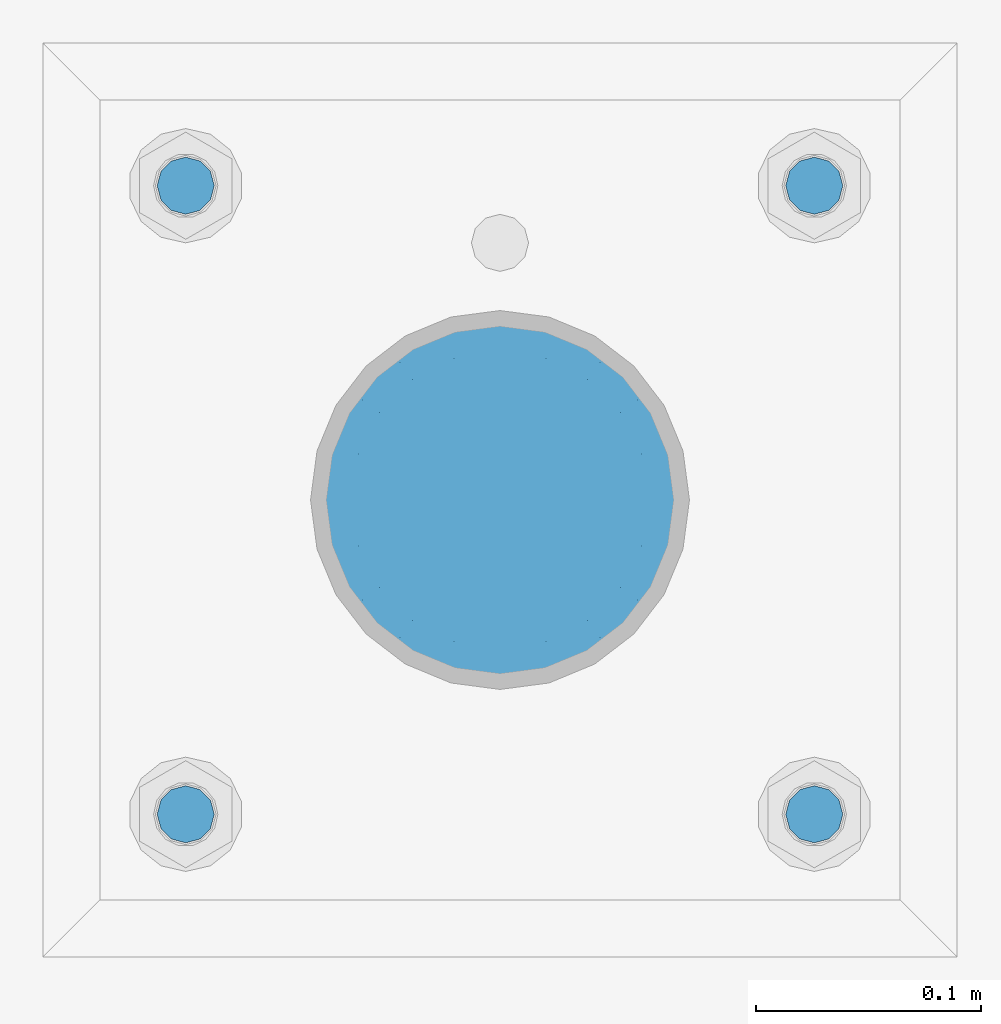
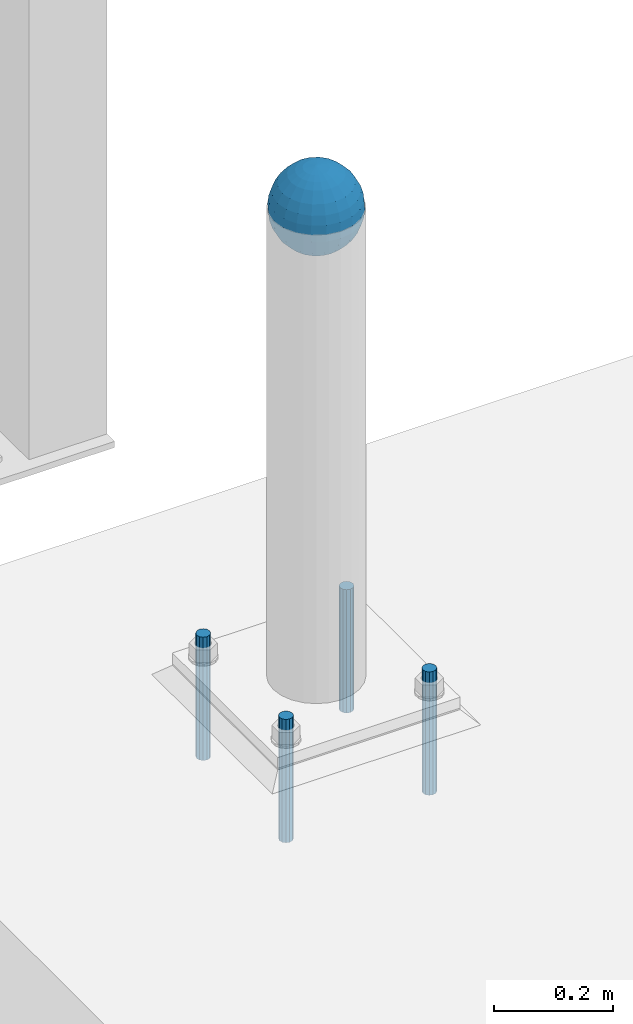
# One storey, part 1578 of 3843: 5 columns, 2 elements without a shape of their own.
"""IFC2X3 building model written with IfcOpenShell, lengths in millimetres."""

from ifc_helpers import new_model, si_unit, frame, origin_with_axes, place, context, subcontext, project, spatial, faceted_brep, material, type_object, element, aggregate, save


model = new_model("IFC2X3")

# Units and contexts
model_context = context("Model", 3, precision=1e-05, world=origin_with_axes())
body_context = subcontext(model_context, "Body", "Model", "MODEL_VIEW")
ifc_project = project(units=[si_unit("LENGTHUNIT", "METRE", prefix="MILLI"), si_unit("AREAUNIT", "SQUARE_METRE"), si_unit("VOLUMEUNIT", "CUBIC_METRE"), si_unit("MASSUNIT", "GRAM", prefix="KILO"), si_unit("TIMEUNIT", "SECOND"), si_unit("PLANEANGLEUNIT", "RADIAN"), si_unit("SOLIDANGLEUNIT", "STERADIAN"), si_unit("THERMODYNAMICTEMPERATUREUNIT", "DEGREE_CELSIUS"), si_unit("LUMINOUSINTENSITYUNIT", "LUMEN")], contexts=[model_context])

# Site, building, storey
site_placement = place(None, origin_with_axes())
site = spatial("IfcSite", under=ifc_project, at=site_placement, CompositionType="ELEMENT")
building_placement = place(site_placement, origin_with_axes())
building = spatial("IfcBuilding", under=site, at=building_placement, Name="Undefined", CompositionType="ELEMENT")
storey_placement = place(building_placement, origin_with_axes())
storey = spatial("IfcBuildingStorey", under=building, at=storey_placement, Name="Undefined", CompositionType="ELEMENT", Elevation=0.0)

# Assembly, column
assembly_1_placement = place(storey_placement, origin_with_axes())
assembly_1 = element("IfcElementAssembly", 1, at=assembly_1_placement, inside=storey, Name="CONC. FILL", AssemblyPlace="NOTDEFINED", PredefinedType="REINFORCEMENT_UNIT")
ifc_material_1 = material(Name="CONCRETE/1500")
column_type_1 = type_object("IfcColumnType", PredefinedType="NOTDEFINED")
column_1_placement = place(assembly_1_placement, frame((42849.8, 91605.1, 31411.8625), z_axis=(-1.0, 0.0, 0.0), x_axis=(0.0, 0.0, 1.0)))
column_1 = element("IfcColumn", 2, at=column_1_placement, type_object=column_type_1, material=ifc_material_1, Name="CONC. FILL", context=body_context, shape_type="Brep", body=[
    faceted_brep([(0.0, 0.0, 2.0), (0.0, -0.619999999995343, 1.89999999999964), (3.36549999999988, -7.1422259999963, 21.9814139999999), (3.36549999999988, 0.0, 23.1139999999996), (0.0, -1.17999999999302, 1.6200000000008), (3.36549999999988, -13.5910319999966, 18.6992260000006), (0.0, -1.61999999999534, 1.18000000000029), (3.36549999999988, -18.699225999997, 13.5910320000003), (0.0, -1.89999999999418, 0.6200000000008), (3.36549999999988, -21.9814139999944, 7.14222599999994), (0.0, -2.0, 0.0), (3.36549999999988, -23.1140000000014, 0.0), (0.0, -1.89999999999418, -0.6200000000008), (3.36549999999988, -21.9814139999944, -7.14222599999994), (0.0, -1.61999999999534, -1.18000000000029), (3.36549999999988, -18.699225999997, -13.5910320000003), (0.0, -1.17999999999302, -1.6200000000008), (3.36549999999988, -13.5910319999966, -18.6992260000006), (0.0, -0.619999999995343, -1.89999999999964), (3.36549999999988, -7.1422259999963, -21.9814139999999), (0.0, 0.0, -2.0), (3.36549999999988, 0.0, -23.1139999999996), (0.0, 0.619999999995343, -1.89999999999964), (3.36549999999988, 7.1422259999963, -21.9814139999999), (0.0, 1.17999999999302, -1.6200000000008), (3.36549999999988, 13.5910319999966, -18.6992260000006), (0.0, 1.61999999999534, -1.18000000000029), (3.36549999999988, 18.699225999997, -13.5910320000003), (0.0, 1.89999999999418, -0.6200000000008), (3.36549999999988, 21.9814139999944, -7.14222599999994), (0.0, 2.0, 0.0), (3.36549999999988, 23.1140000000014, 0.0), (0.0, 1.89999999999418, 0.6200000000008), (3.36549999999988, 21.9814139999944, 7.14222599999994), (0.0, 1.61999999999534, 1.18000000000029), (3.36549999999988, 18.699225999997, 13.5910320000003), (0.0, 1.17999999999302, 1.6200000000008), (3.36549999999988, 13.5910319999966, 18.6992260000006), (0.0, 0.619999999995343, 1.89999999999964), (3.36549999999988, 7.1422259999963, 21.9814139999999), (8.41374999999971, -11.1214661999984, 34.2282018000005), (8.41374999999971, 0.0, 35.9917999999998), (8.41374999999971, -21.1631784000056, 29.1173662000001), (8.41374999999971, -29.1173661999928, 21.1631784000001), (8.41374999999971, -34.2282017999969, 11.1214662000002), (8.41374999999971, -35.9918000000034, 0.0), (8.41374999999971, -34.2282017999969, -11.1214662000002), (8.41374999999971, -29.1173661999928, -21.1631784000001), (8.41374999999971, -21.1631784000056, -29.1173662000001), (8.41374999999971, -11.1214661999984, -34.2282018000005), (8.41374999999971, 0.0, -35.9917999999998), (8.41374999999971, 11.1214661999984, -34.2282018000005), (8.41374999999971, 21.1631784000056, -29.1173662000001), (8.41374999999971, 29.1173661999928, -21.1631784000001), (8.41374999999971, 34.2282017999969, -11.1214662000002), (8.41374999999971, 35.9918000000034, 0.0), (8.41374999999971, 34.2282017999969, 11.1214662000002), (8.41374999999971, 29.1173661999928, 21.1631784000001), (8.41374999999971, 21.1631784000056, 29.1173662000001), (8.41374999999971, 11.1214661999984, 34.2282018000005), (16.8274999999994, -15.3047700000025, 47.1030300000002), (16.8274999999994, 0.0, 49.5300000000007), (16.8274999999994, -29.1236400000053, 40.0697700000001), (16.8274999999994, -40.0697700000019, 29.1236399999998), (16.8274999999994, -47.1030299999984, 15.3047700000006), (16.8274999999994, -49.5299999999988, 0.0), (16.8274999999994, -47.1030299999984, -15.3047700000006), (16.8274999999994, -40.0697700000019, -29.1236399999998), (16.8274999999994, -29.1236400000053, -40.0697700000001), (16.8274999999994, -15.3047700000025, -47.1030300000002), (16.8274999999994, 0.0, -49.5300000000007), (16.8274999999994, 15.3047700000025, -47.1030300000002), (16.8274999999994, 29.1236400000053, -40.0697700000001), (16.8274999999994, 40.0697700000019, -29.1236399999998), (16.8274999999994, 47.1030299999984, -15.3047700000006), (16.8274999999994, 49.5299999999988, 0.0), (16.8274999999994, 47.1030299999984, 15.3047700000006), (16.8274999999994, 40.0697700000019, 29.1236399999998), (16.8274999999994, 29.1236400000053, 40.0697700000001), (16.8274999999994, 15.3047700000025, 47.1030300000002), (33.6549999999988, -20.4063599999936, 62.8040400000009), (33.6549999999988, 0.0, 66.0400000000009), (33.6549999999988, -38.831520000007, 53.4263599999995), (33.6549999999988, -53.4263599999977, 38.8315199999997), (33.6549999999988, -62.8040400000027, 20.4063600000009), (33.6549999999988, -66.0399999999936, 0.0), (33.6549999999988, -62.8040400000027, -20.4063600000009), (33.6549999999988, -53.4263599999977, -38.8315199999997), (33.6549999999988, -38.831520000007, -53.4263599999995), (33.6549999999988, -20.4063599999936, -62.8040400000009), (33.6549999999988, 0.0, -66.0400000000009), (33.6549999999988, 20.4063599999936, -62.8040400000009), (33.6549999999988, 38.831520000007, -53.4263599999995), (33.6549999999988, 53.4263599999977, -38.8315199999997), (33.6549999999988, 62.8040400000027, -20.4063600000009), (33.6549999999988, 66.0399999999936, 0.0), (33.6549999999988, 62.8040400000027, 20.4063600000009), (33.6549999999988, 53.4263599999977, 38.8315199999997), (33.6549999999988, 38.831520000007, 53.4263599999995), (33.6549999999988, 20.4063599999936, 62.8040400000009), (50.4824999999983, -23.3907901500061, 71.9891308499991), (50.4824999999983, 0.0, 75.6983500000006), (50.4824999999983, -44.5106298000028, 61.23996515), (50.4824999999983, -61.2399651500018, 44.5106297999992), (50.4824999999983, -71.9891308499937, 23.3907901500006), (50.4824999999983, -75.698350000006, 0.0), (50.4824999999983, -71.9891308499937, -23.3907901500006), (50.4824999999983, -61.2399651500018, -44.5106297999992), (50.4824999999983, -44.5106298000028, -61.23996515), (50.4824999999983, -23.3907901500061, -71.9891308499991), (50.4824999999983, 0.0, -75.6983500000006), (50.4824999999983, 23.3907901500061, -71.9891308499991), (50.4824999999983, 44.5106298000028, -61.23996515), (50.4824999999983, 61.2399651500018, -44.5106297999992), (50.4824999999983, 71.9891308499937, -23.3907901500006), (50.4824999999983, 75.698350000006, 0.0), (50.4824999999983, 71.9891308499937, 23.3907901500006), (50.4824999999983, 61.2399651500018, 44.5106297999992), (50.4824999999983, 44.5106298000028, 61.23996515), (50.4824999999983, 23.3907901500061, 71.9891308499991), (67.3099999999977, -24.9977910000016, 76.9349490000004), (67.3099999999977, 0.0, 80.8989999999994), (67.3099999999977, -47.5686120000028, 65.4472910000004), (67.3099999999977, -65.447291000004, 47.5686119999991), (67.3099999999977, -76.9349490000022, 24.9977909999998), (67.3099999999977, -80.8990000000049, 0.0), (67.3099999999977, -76.9349490000022, -24.9977909999998), (67.3099999999977, -65.447291000004, -47.5686119999991), (67.3099999999977, -47.5686120000028, -65.4472910000004), (67.3099999999977, -24.9977910000016, -76.9349490000004), (67.3099999999977, 0.0, -80.8989999999994), (67.3099999999977, 24.9977910000016, -76.9349490000004), (67.3099999999977, 47.5686120000028, -65.4472910000004), (67.3099999999977, 65.447291000004, -47.5686119999991), (67.3099999999977, 76.9349490000022, -24.9977909999998), (67.3099999999977, 80.8990000000049, 0.0), (67.3099999999977, 76.9349490000022, 24.9977909999998), (67.3099999999977, 65.447291000004, 47.5686119999991), (67.3099999999977, 47.5686120000028, 65.4472910000004), (67.3099999999977, 24.9977910000016, 76.9349490000004), (84.1374999999935, -25.5079499999993, 78.5050499999998), (84.1374999999935, 0.0, 82.5499999999993), (84.1374999999935, -48.5393999999942, 66.7829500000007), (84.1374999999935, -66.7829499999934, 48.5393999999997), (84.1374999999935, -78.505050000007, 25.5079499999993), (84.1374999999935, -82.5500000000029, 0.0), (84.1374999999935, -78.505050000007, -25.5079499999993), (84.1374999999935, -66.7829499999934, -48.5393999999997), (84.1374999999935, -48.5393999999942, -66.7829500000007), (84.1374999999935, -25.5079499999993, -78.5050499999998), (84.1374999999935, 0.0, -82.5499999999993), (84.1374999999935, 25.5079499999993, -78.5050499999998), (84.1374999999935, 48.5393999999942, -66.7829500000007), (84.1374999999935, 66.7829499999934, -48.5393999999997), (84.1374999999935, 78.505050000007, -25.5079499999993), (84.1374999999935, 82.5500000000029, 0.0), (84.1374999999935, 78.505050000007, 25.5079499999993), (84.1374999999935, 66.7829499999934, 48.5393999999997), (84.1374999999935, 48.5393999999942, 66.7829500000007), (84.1374999999935, 25.5079499999993, 78.5050499999998), (100.964999999993, -24.9977910000016, 76.9349490000004), (100.964999999993, 0.0, 80.8989999999994), (100.964999999993, -47.5686120000028, 65.4472910000004), (100.964999999993, -65.447291000004, 47.5686119999991), (100.964999999993, -76.9349490000022, 24.9977909999998), (100.964999999993, -80.8990000000049, 0.0), (100.964999999993, -76.9349490000022, -24.9977909999998), (100.964999999993, -65.447291000004, -47.5686119999991), (100.964999999993, -47.5686120000028, -65.4472910000004), (100.964999999993, -24.9977910000016, -76.9349490000004), (100.964999999993, 0.0, -80.8989999999994), (100.964999999993, 24.9977910000016, -76.9349490000004), (100.964999999993, 47.5686120000028, -65.4472910000004), (100.964999999993, 65.447291000004, -47.5686119999991), (100.964999999993, 76.9349490000022, -24.9977909999998), (100.964999999993, 80.8990000000049, 0.0), (100.964999999993, 76.9349490000022, 24.9977909999998), (100.964999999993, 65.447291000004, 47.5686119999991), (100.964999999993, 47.5686120000028, 65.4472910000004), (100.964999999993, 24.9977910000016, 76.9349490000004), (117.792499999992, -23.3907901500061, 71.9891308499991), (117.792499999992, 0.0, 75.6983500000006), (117.792499999992, -44.5106298000028, 61.23996515), (117.792499999992, -61.2399651500018, 44.5106297999992), (117.792499999992, -71.9891308499937, 23.3907901500006), (117.792499999992, -75.698350000006, 0.0), (117.792499999992, -71.9891308499937, -23.3907901500006), (117.792499999992, -61.2399651500018, -44.5106297999992), (117.792499999992, -44.5106298000028, -61.23996515), (117.792499999992, -23.3907901500061, -71.9891308499991), (117.792499999992, 0.0, -75.6983500000006), (117.792499999992, 23.3907901500061, -71.9891308499991), (117.792499999992, 44.5106298000028, -61.23996515), (117.792499999992, 61.2399651500018, -44.5106297999992), (117.792499999992, 71.9891308499937, -23.3907901500006), (117.792499999992, 75.698350000006, 0.0), (117.792499999992, 71.9891308499937, 23.3907901500006), (117.792499999992, 61.2399651500018, 44.5106297999992), (117.792499999992, 44.5106298000028, 61.23996515), (117.792499999992, 23.3907901500061, 71.9891308499991), (134.619999999992, -20.4063599999936, 62.8040400000009), (134.619999999992, 0.0, 66.0400000000009), (134.619999999992, -38.831520000007, 53.4263599999995), (134.619999999992, -53.4263599999977, 38.8315199999997), (134.619999999992, -62.8040400000027, 20.4063600000009), (134.619999999992, -66.0399999999936, 0.0), (134.619999999992, -62.8040400000027, -20.4063600000009), (134.619999999992, -53.4263599999977, -38.8315199999997), (134.619999999992, -38.831520000007, -53.4263599999995), (134.619999999992, -20.4063599999936, -62.8040400000009), (134.619999999992, 0.0, -66.0400000000009), (134.619999999992, 20.4063599999936, -62.8040400000009), (134.619999999992, 38.831520000007, -53.4263599999995), (134.619999999992, 53.4263599999977, -38.8315199999997), (134.619999999992, 62.8040400000027, -20.4063600000009), (134.619999999992, 66.0399999999936, 0.0), (134.619999999992, 62.8040400000027, 20.4063600000009), (134.619999999992, 53.4263599999977, 38.8315199999997), (134.619999999992, 38.831520000007, 53.4263599999995), (134.619999999992, 20.4063599999936, 62.8040400000009), (151.447499999991, -15.3047700000025, 47.1030300000002), (151.447499999991, 0.0, 49.5300000000007), (151.447499999991, -29.1236400000053, 40.0697700000001), (151.447499999991, -40.0697700000019, 29.1236399999998), (151.447499999991, -47.1030299999984, 15.3047700000006), (151.447499999991, -49.5299999999988, 0.0), (151.447499999991, -47.1030299999984, -15.3047700000006), (151.447499999991, -40.0697700000019, -29.1236399999998), (151.447499999991, -29.1236400000053, -40.0697700000001), (151.447499999991, -15.3047700000025, -47.1030300000002), (151.447499999991, 0.0, -49.5300000000007), (151.447499999991, 15.3047700000025, -47.1030300000002), (151.447499999991, 29.1236400000053, -40.0697700000001), (151.447499999991, 40.0697700000019, -29.1236399999998), (151.447499999991, 47.1030299999984, -15.3047700000006), (151.447499999991, 49.5299999999988, 0.0), (151.447499999991, 47.1030299999984, 15.3047700000006), (151.447499999991, 40.0697700000019, 29.1236399999998), (151.447499999991, 29.1236400000053, 40.0697700000001), (151.447499999991, 15.3047700000025, 47.1030300000002), (159.861249999991, -11.1214661999984, 34.2282018000005), (159.861249999991, 0.0, 35.9917999999998), (159.861249999991, -21.1631784000056, 29.1173662000001), (159.861249999991, -29.1173661999928, 21.1631784000001), (159.861249999991, -34.2282017999969, 11.1214662000002), (159.861249999991, -35.9918000000034, 0.0), (159.861249999991, -34.2282017999969, -11.1214662000002), (159.861249999991, -29.1173661999928, -21.1631784000001), (159.861249999991, -21.1631784000056, -29.1173662000001), (159.861249999991, -11.1214661999984, -34.2282018000005), (159.861249999991, 0.0, -35.9917999999998), (159.861249999991, 11.1214661999984, -34.2282018000005), (159.861249999991, 21.1631784000056, -29.1173662000001), (159.861249999991, 29.1173661999928, -21.1631784000001), (159.861249999991, 34.2282017999969, -11.1214662000002), (159.861249999991, 35.9918000000034, 0.0), (159.861249999991, 34.2282017999969, 11.1214662000002), (159.861249999991, 29.1173661999928, 21.1631784000001), (159.861249999991, 21.1631784000056, 29.1173662000001), (159.861249999991, 11.1214661999984, 34.2282018000005), (164.909499999991, -7.1422259999963, 21.9814139999999), (164.909499999991, 0.0, 23.1139999999996), (164.909499999991, -13.5910319999966, 18.6992260000006), (164.909499999991, -18.699225999997, 13.5910320000003), (164.909499999991, -21.9814139999944, 7.14222599999994), (164.909499999991, -23.1140000000014, 0.0), (164.909499999991, -21.9814139999944, -7.14222599999994), (164.909499999991, -18.699225999997, -13.5910320000003), (164.909499999991, -13.5910319999966, -18.6992260000006), (164.909499999991, -7.1422259999963, -21.9814139999999), (164.909499999991, 0.0, -23.1139999999996), (164.909499999991, 7.1422259999963, -21.9814139999999), (164.909499999991, 13.5910319999966, -18.6992260000006), (164.909499999991, 18.699225999997, -13.5910320000003), (164.909499999991, 21.9814139999944, -7.14222599999994), (164.909499999991, 23.1140000000014, 0.0), (164.909499999991, 21.9814139999944, 7.14222599999994), (164.909499999991, 18.699225999997, 13.5910320000003), (164.909499999991, 13.5910319999966, 18.6992260000006), (164.909499999991, 7.1422259999963, 21.9814139999999), (168.274999999991, -0.619999999995343, 1.89999999999964), (168.274999999991, 0.0, 2.0), (168.274999999991, -1.17999999999302, 1.6200000000008), (168.274999999991, -1.61999999999534, 1.18000000000029), (168.274999999991, -1.89999999999418, 0.6200000000008), (168.274999999991, -2.0, 0.0), (168.274999999991, -1.89999999999418, -0.6200000000008), (168.274999999991, -1.61999999999534, -1.18000000000029), (168.274999999991, -1.17999999999302, -1.6200000000008), (168.274999999991, -0.619999999995343, -1.89999999999964), (168.274999999991, 0.0, -2.0), (168.274999999991, 0.619999999995343, -1.89999999999964), (168.274999999991, 1.17999999999302, -1.6200000000008), (168.274999999991, 1.61999999999534, -1.18000000000029), (168.274999999991, 1.89999999999418, -0.6200000000008), (168.274999999991, 2.0, 0.0), (168.274999999991, 1.89999999999418, 0.6200000000008), (168.274999999991, 1.61999999999534, 1.18000000000029), (168.274999999991, 1.17999999999302, 1.6200000000008), (168.274999999991, 0.619999999995343, 1.89999999999964)], [[[0, 1, 2, 3]], [[1, 4, 5, 2]], [[4, 6, 7, 5]], [[6, 8, 9, 7]], [[8, 10, 11, 9]], [[10, 12, 13, 11]], [[12, 14, 15, 13]], [[14, 16, 17, 15]], [[16, 18, 19, 17]], [[18, 20, 21, 19]], [[20, 22, 23, 21]], [[22, 24, 25, 23]], [[24, 26, 27, 25]], [[26, 28, 29, 27]], [[28, 30, 31, 29]], [[30, 32, 33, 31]], [[32, 34, 35, 33]], [[34, 36, 37, 35]], [[36, 38, 39, 37]], [[38, 0, 3, 39]], [[38, 36, 34, 32, 30, 28, 26, 24, 22, 20, 18, 16, 14, 12, 10, 8, 6, 4, 1, 0]], [[3, 2, 40, 41]], [[2, 5, 42, 40]], [[5, 7, 43, 42]], [[7, 9, 44, 43]], [[9, 11, 45, 44]], [[11, 13, 46, 45]], [[13, 15, 47, 46]], [[15, 17, 48, 47]], [[17, 19, 49, 48]], [[19, 21, 50, 49]], [[21, 23, 51, 50]], [[23, 25, 52, 51]], [[25, 27, 53, 52]], [[27, 29, 54, 53]], [[29, 31, 55, 54]], [[31, 33, 56, 55]], [[33, 35, 57, 56]], [[35, 37, 58, 57]], [[37, 39, 59, 58]], [[39, 3, 41, 59]], [[41, 40, 60, 61]], [[40, 42, 62, 60]], [[42, 43, 63, 62]], [[43, 44, 64, 63]], [[44, 45, 65, 64]], [[45, 46, 66, 65]], [[46, 47, 67, 66]], [[47, 48, 68, 67]], [[48, 49, 69, 68]], [[49, 50, 70, 69]], [[50, 51, 71, 70]], [[51, 52, 72, 71]], [[52, 53, 73, 72]], [[53, 54, 74, 73]], [[54, 55, 75, 74]], [[55, 56, 76, 75]], [[56, 57, 77, 76]], [[57, 58, 78, 77]], [[58, 59, 79, 78]], [[59, 41, 61, 79]], [[61, 60, 80, 81]], [[60, 62, 82, 80]], [[62, 63, 83, 82]], [[63, 64, 84, 83]], [[64, 65, 85, 84]], [[65, 66, 86, 85]], [[66, 67, 87, 86]], [[67, 68, 88, 87]], [[68, 69, 89, 88]], [[69, 70, 90, 89]], [[70, 71, 91, 90]], [[71, 72, 92, 91]], [[72, 73, 93, 92]], [[73, 74, 94, 93]], [[74, 75, 95, 94]], [[75, 76, 96, 95]], [[76, 77, 97, 96]], [[77, 78, 98, 97]], [[78, 79, 99, 98]], [[79, 61, 81, 99]], [[81, 80, 100, 101]], [[80, 82, 102, 100]], [[82, 83, 103, 102]], [[83, 84, 104, 103]], [[84, 85, 105, 104]], [[85, 86, 106, 105]], [[86, 87, 107, 106]], [[87, 88, 108, 107]], [[88, 89, 109, 108]], [[89, 90, 110, 109]], [[90, 91, 111, 110]], [[91, 92, 112, 111]], [[92, 93, 113, 112]], [[93, 94, 114, 113]], [[94, 95, 115, 114]], [[95, 96, 116, 115]], [[96, 97, 117, 116]], [[97, 98, 118, 117]], [[98, 99, 119, 118]], [[99, 81, 101, 119]], [[101, 100, 120, 121]], [[100, 102, 122, 120]], [[102, 103, 123, 122]], [[103, 104, 124, 123]], [[104, 105, 125, 124]], [[105, 106, 126, 125]], [[106, 107, 127, 126]], [[107, 108, 128, 127]], [[108, 109, 129, 128]], [[109, 110, 130, 129]], [[110, 111, 131, 130]], [[111, 112, 132, 131]], [[112, 113, 133, 132]], [[113, 114, 134, 133]], [[114, 115, 135, 134]], [[115, 116, 136, 135]], [[116, 117, 137, 136]], [[117, 118, 138, 137]], [[118, 119, 139, 138]], [[119, 101, 121, 139]], [[121, 120, 140, 141]], [[120, 122, 142, 140]], [[122, 123, 143, 142]], [[123, 124, 144, 143]], [[124, 125, 145, 144]], [[125, 126, 146, 145]], [[126, 127, 147, 146]], [[127, 128, 148, 147]], [[128, 129, 149, 148]], [[129, 130, 150, 149]], [[130, 131, 151, 150]], [[131, 132, 152, 151]], [[132, 133, 153, 152]], [[133, 134, 154, 153]], [[134, 135, 155, 154]], [[135, 136, 156, 155]], [[136, 137, 157, 156]], [[137, 138, 158, 157]], [[138, 139, 159, 158]], [[139, 121, 141, 159]], [[141, 140, 160, 161]], [[140, 142, 162, 160]], [[142, 143, 163, 162]], [[143, 144, 164, 163]], [[144, 145, 165, 164]], [[145, 146, 166, 165]], [[146, 147, 167, 166]], [[147, 148, 168, 167]], [[148, 149, 169, 168]], [[149, 150, 170, 169]], [[150, 151, 171, 170]], [[151, 152, 172, 171]], [[152, 153, 173, 172]], [[153, 154, 174, 173]], [[154, 155, 175, 174]], [[155, 156, 176, 175]], [[156, 157, 177, 176]], [[157, 158, 178, 177]], [[158, 159, 179, 178]], [[159, 141, 161, 179]], [[161, 160, 180, 181]], [[160, 162, 182, 180]], [[162, 163, 183, 182]], [[163, 164, 184, 183]], [[164, 165, 185, 184]], [[165, 166, 186, 185]], [[166, 167, 187, 186]], [[167, 168, 188, 187]], [[168, 169, 189, 188]], [[169, 170, 190, 189]], [[170, 171, 191, 190]], [[171, 172, 192, 191]], [[172, 173, 193, 192]], [[173, 174, 194, 193]], [[174, 175, 195, 194]], [[175, 176, 196, 195]], [[176, 177, 197, 196]], [[177, 178, 198, 197]], [[178, 179, 199, 198]], [[179, 161, 181, 199]], [[181, 180, 200, 201]], [[180, 182, 202, 200]], [[182, 183, 203, 202]], [[183, 184, 204, 203]], [[184, 185, 205, 204]], [[185, 186, 206, 205]], [[186, 187, 207, 206]], [[187, 188, 208, 207]], [[188, 189, 209, 208]], [[189, 190, 210, 209]], [[190, 191, 211, 210]], [[191, 192, 212, 211]], [[192, 193, 213, 212]], [[193, 194, 214, 213]], [[194, 195, 215, 214]], [[195, 196, 216, 215]], [[196, 197, 217, 216]], [[197, 198, 218, 217]], [[198, 199, 219, 218]], [[199, 181, 201, 219]], [[201, 200, 220, 221]], [[200, 202, 222, 220]], [[202, 203, 223, 222]], [[203, 204, 224, 223]], [[204, 205, 225, 224]], [[205, 206, 226, 225]], [[206, 207, 227, 226]], [[207, 208, 228, 227]], [[208, 209, 229, 228]], [[209, 210, 230, 229]], [[210, 211, 231, 230]], [[211, 212, 232, 231]], [[212, 213, 233, 232]], [[213, 214, 234, 233]], [[214, 215, 235, 234]], [[215, 216, 236, 235]], [[216, 217, 237, 236]], [[217, 218, 238, 237]], [[218, 219, 239, 238]], [[219, 201, 221, 239]], [[221, 220, 240, 241]], [[220, 222, 242, 240]], [[222, 223, 243, 242]], [[223, 224, 244, 243]], [[224, 225, 245, 244]], [[225, 226, 246, 245]], [[226, 227, 247, 246]], [[227, 228, 248, 247]], [[228, 229, 249, 248]], [[229, 230, 250, 249]], [[230, 231, 251, 250]], [[231, 232, 252, 251]], [[232, 233, 253, 252]], [[233, 234, 254, 253]], [[234, 235, 255, 254]], [[235, 236, 256, 255]], [[236, 237, 257, 256]], [[237, 238, 258, 257]], [[238, 239, 259, 258]], [[239, 221, 241, 259]], [[241, 240, 260, 261]], [[240, 242, 262, 260]], [[242, 243, 263, 262]], [[243, 244, 264, 263]], [[244, 245, 265, 264]], [[245, 246, 266, 265]], [[246, 247, 267, 266]], [[247, 248, 268, 267]], [[248, 249, 269, 268]], [[249, 250, 270, 269]], [[250, 251, 271, 270]], [[251, 252, 272, 271]], [[252, 253, 273, 272]], [[253, 254, 274, 273]], [[254, 255, 275, 274]], [[255, 256, 276, 275]], [[256, 257, 277, 276]], [[257, 258, 278, 277]], [[258, 259, 279, 278]], [[259, 241, 261, 279]], [[261, 260, 280, 281]], [[260, 262, 282, 280]], [[262, 263, 283, 282]], [[263, 264, 284, 283]], [[264, 265, 285, 284]], [[265, 266, 286, 285]], [[266, 267, 287, 286]], [[267, 268, 288, 287]], [[268, 269, 289, 288]], [[269, 270, 290, 289]], [[270, 271, 291, 290]], [[271, 272, 292, 291]], [[272, 273, 293, 292]], [[273, 274, 294, 293]], [[274, 275, 295, 294]], [[275, 276, 296, 295]], [[276, 277, 297, 296]], [[277, 278, 298, 297]], [[278, 279, 299, 298]], [[279, 261, 281, 299]], [[282, 283, 284, 285, 286, 287, 288, 289, 290, 291, 292, 293, 294, 295, 296, 297, 298, 299, 281, 280]]]),
])
aggregate(assembly_1, [column_1])

# Assembly, columns
assembly_2_placement = place(storey_placement, origin_with_axes())
assembly_2 = element("IfcElementAssembly", 3, at=assembly_2_placement, inside=storey, Name="TEMPLATE", AssemblyPlace="NOTDEFINED", PredefinedType="RIGID_FRAME")
ifc_material_2 = material(Name="STEEL/316 SS")
column_type_2 = type_object("IfcColumnType", PredefinedType="NOTDEFINED")
column_2_placement = place(assembly_2_placement, frame((42989.5, 91465.4, 30581.6), z_axis=(1.0, 0.0, 0.0), x_axis=(0.0, 0.0, -1.0)))
column_2 = element("IfcColumn", 4, at=column_2_placement, type_object=column_type_2, material=ifc_material_2, Name="ANCHOR_ROD", context=body_context, shape_type="Brep", body=[
    faceted_brep([(0.0, -12.6999999999971, 0.0), (0.0, -10.9985226280696, -6.34999999999854), (253.999, -10.9985226280696, -6.34999999999854), (253.999, -12.6999999999971, 0.0), (0.0, -6.35000000000582, -10.9985226280623), (253.999, -6.35000000000582, -10.9985226280623), (0.0, 0.0, -12.6999999999971), (253.999, 0.0, -12.6999999999971), (0.0, 6.35000000000582, -10.9985226280623), (253.999, 6.35000000000582, -10.9985226280623), (0.0, 10.9985226280696, -6.34999999999854), (253.999, 10.9985226280696, -6.34999999999854), (0.0, 12.6999999999971, 0.0), (253.999, 12.6999999999971, 0.0), (0.0, 10.9985226280696, 6.34999999999854), (253.999, 10.9985226280696, 6.34999999999854), (0.0, 6.35000000000582, 10.9985226280623), (253.999, 6.35000000000582, 10.9985226280623), (0.0, 0.0, 12.6999999999971), (253.999, 0.0, 12.6999999999971), (0.0, -6.35000000000582, 10.9985226280623), (253.999, -6.35000000000582, 10.9985226280623), (0.0, -10.9985226280696, 6.34999999999854), (253.999, -10.9985226280696, 6.34999999999854)], [[[0, 1, 2, 3]], [[1, 4, 5, 2]], [[4, 6, 7, 5]], [[6, 8, 9, 7]], [[8, 10, 11, 9]], [[10, 12, 13, 11]], [[12, 14, 15, 13]], [[14, 16, 17, 15]], [[16, 18, 19, 17]], [[18, 20, 21, 19]], [[20, 22, 23, 21]], [[22, 0, 3, 23]], [[5, 7, 9, 11, 13, 15, 17, 19, 21, 23, 3, 2]], [[22, 20, 18, 16, 14, 12, 10, 8, 6, 4, 1, 0]]]),
])
column_3_placement = place(assembly_2_placement, frame((42989.5, 91744.8, 30581.6), z_axis=(-1.0, 0.0, 0.0), x_axis=(0.0, 0.0, -1.0)))
column_3 = element("IfcColumn", 5, at=column_3_placement, type_object=column_type_2, material=ifc_material_2, Name="ANCHOR_ROD", context=body_context, shape_type="Brep", body=[
    faceted_brep([(0.0, -12.6999999999971, 0.0), (0.0, -10.9985226280696, -6.34999999999854), (253.999, -10.9985226280696, -6.34999999999854), (253.999, -12.6999999999971, 0.0), (0.0, -6.35000000000582, -10.9985226280623), (253.999, -6.35000000000582, -10.9985226280623), (0.0, 0.0, -12.6999999999971), (253.999, 0.0, -12.6999999999971), (0.0, 6.35000000000582, -10.9985226280623), (253.999, 6.35000000000582, -10.9985226280623), (0.0, 10.9985226280696, -6.34999999999854), (253.999, 10.9985226280696, -6.34999999999854), (0.0, 12.6999999999971, 0.0), (253.999, 12.6999999999971, 0.0), (0.0, 10.9985226280696, 6.34999999999854), (253.999, 10.9985226280696, 6.34999999999854), (0.0, 6.35000000000582, 10.9985226280623), (253.999, 6.35000000000582, 10.9985226280623), (0.0, 0.0, 12.6999999999971), (253.999, 0.0, 12.6999999999971), (0.0, -6.35000000000582, 10.9985226280623), (253.999, -6.35000000000582, 10.9985226280623), (0.0, -10.9985226280696, 6.34999999999854), (253.999, -10.9985226280696, 6.34999999999854)], [[[0, 1, 2, 3]], [[1, 4, 5, 2]], [[4, 6, 7, 5]], [[6, 8, 9, 7]], [[8, 10, 11, 9]], [[10, 12, 13, 11]], [[12, 14, 15, 13]], [[14, 16, 17, 15]], [[16, 18, 19, 17]], [[18, 20, 21, 19]], [[20, 22, 23, 21]], [[22, 0, 3, 23]], [[5, 7, 9, 11, 13, 15, 17, 19, 21, 23, 3, 2]], [[22, 20, 18, 16, 14, 12, 10, 8, 6, 4, 1, 0]]]),
])
column_4_placement = place(assembly_2_placement, frame((42710.1, 91465.4, 30581.6), z_axis=(1.0, 0.0, 0.0), x_axis=(0.0, 0.0, -1.0)))
column_4 = element("IfcColumn", 6, at=column_4_placement, type_object=column_type_2, material=ifc_material_2, Name="ANCHOR_ROD", context=body_context, shape_type="Brep", body=[
    faceted_brep([(0.0, -12.6999999999971, 0.0), (0.0, -10.9985226280696, -6.34999999999854), (253.999, -10.9985226280696, -6.34999999999854), (253.999, -12.6999999999971, 0.0), (0.0, -6.35000000000582, -10.9985226280623), (253.999, -6.35000000000582, -10.9985226280623), (0.0, 0.0, -12.6999999999971), (253.999, 0.0, -12.6999999999971), (0.0, 6.35000000000582, -10.9985226280623), (253.999, 6.35000000000582, -10.9985226280623), (0.0, 10.9985226280696, -6.34999999999854), (253.999, 10.9985226280696, -6.34999999999854), (0.0, 12.6999999999971, 0.0), (253.999, 12.6999999999971, 0.0), (0.0, 10.9985226280696, 6.34999999999854), (253.999, 10.9985226280696, 6.34999999999854), (0.0, 6.35000000000582, 10.9985226280623), (253.999, 6.35000000000582, 10.9985226280623), (0.0, 0.0, 12.6999999999971), (253.999, 0.0, 12.6999999999971), (0.0, -6.35000000000582, 10.9985226280623), (253.999, -6.35000000000582, 10.9985226280623), (0.0, -10.9985226280696, 6.34999999999854), (253.999, -10.9985226280696, 6.34999999999854)], [[[0, 1, 2, 3]], [[1, 4, 5, 2]], [[4, 6, 7, 5]], [[6, 8, 9, 7]], [[8, 10, 11, 9]], [[10, 12, 13, 11]], [[12, 14, 15, 13]], [[14, 16, 17, 15]], [[16, 18, 19, 17]], [[18, 20, 21, 19]], [[20, 22, 23, 21]], [[22, 0, 3, 23]], [[5, 7, 9, 11, 13, 15, 17, 19, 21, 23, 3, 2]], [[22, 20, 18, 16, 14, 12, 10, 8, 6, 4, 1, 0]]]),
])
column_5_placement = place(assembly_2_placement, frame((42710.1, 91744.8, 30581.6), z_axis=(-1.0, 0.0, 0.0), x_axis=(0.0, 0.0, -1.0)))
column_5 = element("IfcColumn", 7, at=column_5_placement, type_object=column_type_2, material=ifc_material_2, Name="ANCHOR_ROD", context=body_context, shape_type="Brep", body=[
    faceted_brep([(0.0, -12.6999999999971, 0.0), (0.0, -10.9985226280696, -6.34999999999854), (253.999, -10.9985226280696, -6.34999999999854), (253.999, -12.6999999999971, 0.0), (0.0, -6.35000000000582, -10.9985226280623), (253.999, -6.35000000000582, -10.9985226280623), (0.0, 0.0, -12.6999999999971), (253.999, 0.0, -12.6999999999971), (0.0, 6.35000000000582, -10.9985226280623), (253.999, 6.35000000000582, -10.9985226280623), (0.0, 10.9985226280696, -6.34999999999854), (253.999, 10.9985226280696, -6.34999999999854), (0.0, 12.6999999999971, 0.0), (253.999, 12.6999999999971, 0.0), (0.0, 10.9985226280696, 6.34999999999854), (253.999, 10.9985226280696, 6.34999999999854), (0.0, 6.35000000000582, 10.9985226280623), (253.999, 6.35000000000582, 10.9985226280623), (0.0, 0.0, 12.6999999999971), (253.999, 0.0, 12.6999999999971), (0.0, -6.35000000000582, 10.9985226280623), (253.999, -6.35000000000582, 10.9985226280623), (0.0, -10.9985226280696, 6.34999999999854), (253.999, -10.9985226280696, 6.34999999999854)], [[[0, 1, 2, 3]], [[1, 4, 5, 2]], [[4, 6, 7, 5]], [[6, 8, 9, 7]], [[8, 10, 11, 9]], [[10, 12, 13, 11]], [[12, 14, 15, 13]], [[14, 16, 17, 15]], [[16, 18, 19, 17]], [[18, 20, 21, 19]], [[20, 22, 23, 21]], [[22, 0, 3, 23]], [[5, 7, 9, 11, 13, 15, 17, 19, 21, 23, 3, 2]], [[22, 20, 18, 16, 14, 12, 10, 8, 6, 4, 1, 0]]]),
])
aggregate(assembly_2, [column_2, column_3, column_4, column_5])

save(model, "model.ifc")
